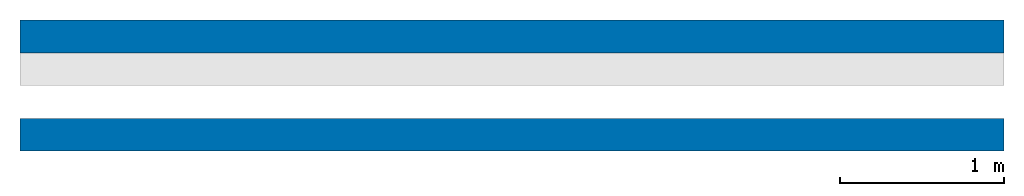
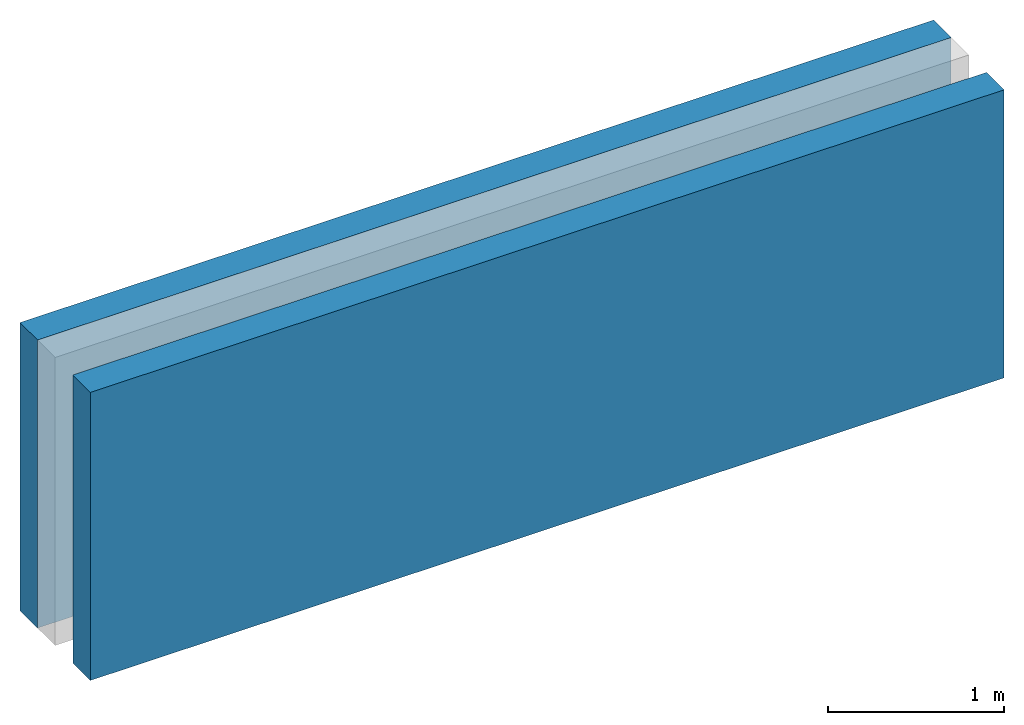
# One storey, part 1 of 2: 2 walls, 1 opening.
"""IFC4 building model written with IfcOpenShell, lengths in metres."""

from ifc_helpers import new_model, si_unit, frame, frame_2d, origin_with_axes, place, context, subcontext, project, spatial, polygons, material, element, save


model = new_model("IFC4")

# Units and contexts
model_context = context("Model", 3, precision=1e-05, world=origin_with_axes())
plan_context = context("Plan", 2, precision=1e-05, world=frame_2d((0.0, 0.0, 0.0), x_axis=(1.0, 0.0, 0.0)))
body_context = subcontext(model_context, "Body", "Model", "MODEL_VIEW")
ifc_project = project(units=[si_unit("VOLUMEUNIT", "CUBIC_METRE"), si_unit("LENGTHUNIT", "METRE"), si_unit("AREAUNIT", "SQUARE_METRE")], contexts=[model_context, plan_context])

# Site, building, storey
site_placement = place(None, origin_with_axes())
site = spatial("IfcSite", under=ifc_project, at=site_placement)
building_placement = place(site_placement, origin_with_axes())
building = spatial("IfcBuilding", under=site, at=building_placement, Name="Building")
storey_placement = place(building_placement, origin_with_axes())
storey = spatial("IfcBuildingStorey", under=building, at=storey_placement, Name="Storey")

# Wall
ifc_material_1 = material(Name="brick")
wall_1_placement = place(storey_placement, frame((6.0, 0.0, 0.0), z_axis=(0.0, 0.0, 1.0), x_axis=(1.0, 0.0, 0.0)))
element("IfcWall", 1, at=wall_1_placement, inside=storey, material=ifc_material_1, Name="outer_wall", PredefinedType="ELEMENTEDWALL", context=body_context, shape_type="Tessellation", body=[
    polygons([(-6.0, 0.0, 0.0), (-6.0, 0.0, 2.0), (-6.0, 0.199999988079071, 0.0), (-6.0, 0.199999988079071, 2.0), (0.0, 0.0, 0.0), (0.0, 0.0, 2.0), (0.0, 0.199999988079071, 0.0), (0.0, 0.199999988079071, 2.0)], [[[1, 2, 4, 3]], [[3, 4, 8, 7]], [[7, 8, 6, 5]], [[5, 6, 2, 1]], [[3, 7, 5, 1]], [[8, 4, 2, 6]]]),
])

# Wall, opening
ifc_material_2 = material(Name="concrete")
wall_2_placement = place(storey_placement, frame((6.0, 0.600000023841858, 0.0), z_axis=(0.0, 0.0, 1.0), x_axis=(1.0, 0.0, 0.0)))
wall_2 = element("IfcWall", 2, at=wall_2_placement, inside=storey, material=ifc_material_2, Name="inside_wall", PredefinedType="ELEMENTEDWALL", context=body_context, shape_type="Tessellation", body=[
    polygons([(-6.0, 0.0, 0.0), (-6.0, 0.0, 2.0), (-6.0, 0.199999988079071, 0.0), (-6.0, 0.199999988079071, 2.0), (0.0, 0.0, 0.0), (0.0, 0.0, 2.0), (0.0, 0.199999988079071, 0.0), (0.0, 0.199999988079071, 2.0)], [[[1, 2, 4, 3]], [[3, 4, 8, 7]], [[7, 8, 6, 5]], [[5, 6, 2, 1]], [[3, 7, 5, 1]], [[8, 4, 2, 6]]]),
])
opening_placement = place(wall_2_placement, frame((-4.5, 0.200000286102295, 0.0), z_axis=(0.0, 0.0, 1.0), x_axis=(1.0, 0.0, 0.0)))
element("IfcOpeningElement", 3, at=opening_placement, cuts=wall_2, Name="Opening", context=body_context, shape_type="Tessellation", body=[
    polygons([(-0.999115943908691, -0.200000286102295, 0.0), (-0.999115943908691, -0.200000286102295, 1.0), (-0.999115943908691, 0.0, 0.0), (-0.999115943908691, 0.0, 1.0), (0.0, -0.200000286102295, 0.0), (0.0, -0.200000286102295, 1.0), (0.0, 0.0, 0.0), (0.0, 0.0, 1.0)], [[[1, 2, 4, 3]], [[3, 4, 8, 7]], [[7, 8, 6, 5]], [[5, 6, 2, 1]], [[3, 7, 5, 1]], [[8, 4, 2, 6]]]),
])

save(model, "model.ifc")
